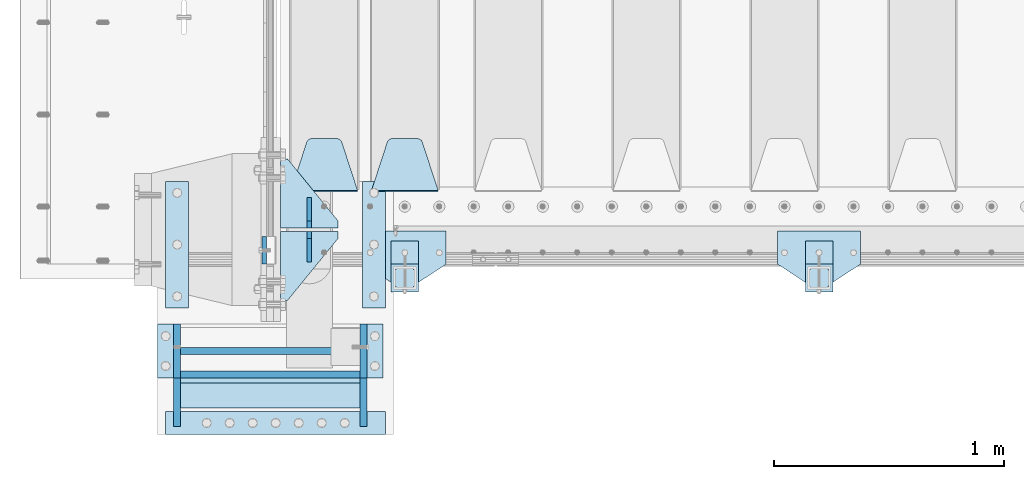
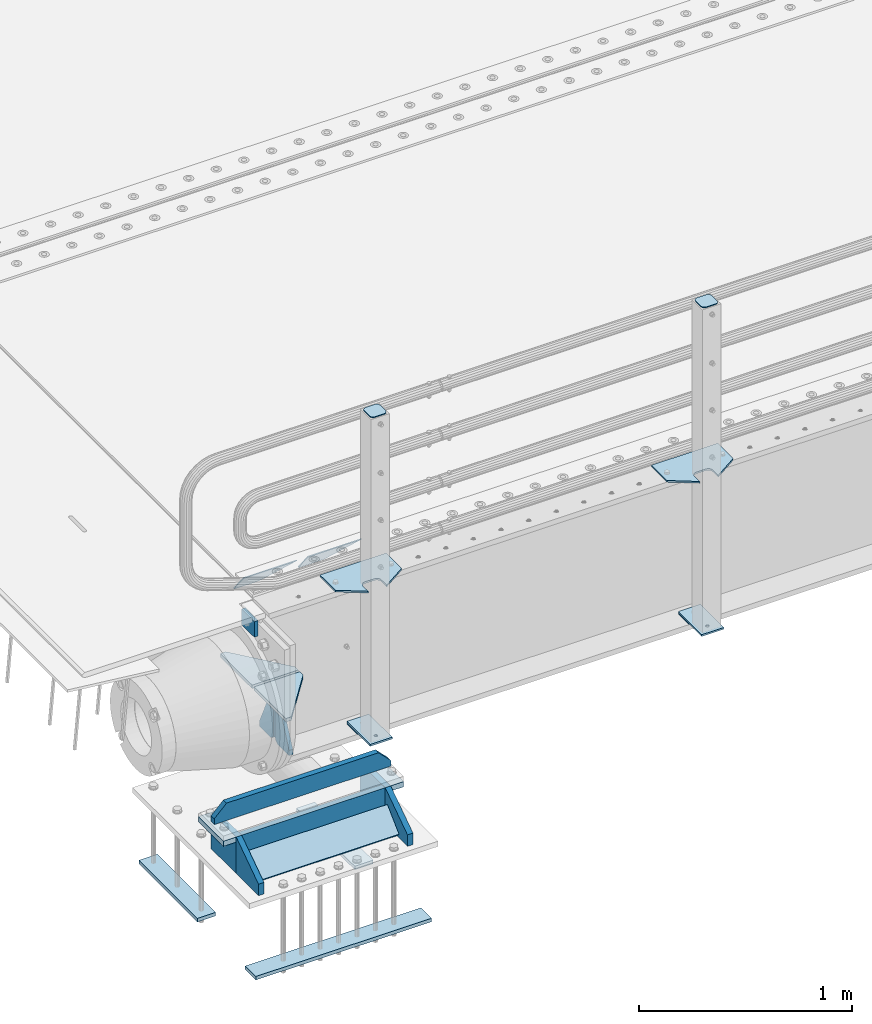
# One storey, part 196 of 247: 27 plates.
"""IFC2X3 building model written with IfcOpenShell, lengths in millimetres."""

import ifcopenshell
import ifcopenshell.guid

model = None  # the IFC model being written
_history = None  # IfcOwnerHistory: only IFC2X3 demands one
_inside = {}  # id of a spatial element -> (the spatial element, [elements in it])
_under = {}  # id of a project, library or spatial element -> (it, [spatial elements below it])
_declared = {}  # id of a project -> (the project, [libraries it declares])
_typed = {}  # id of a type object -> (the type object, [elements of that type])
_made_of = {}  # id of a material, layer set ... -> (it, [elements and type objects made of it])


def new_model(schema):
    """Start an empty IFC model of exactly this schema.

    Asked for "IFC4X3", IfcOpenShell would pick the latest addendum, in which some entities
    have other attributes; the version numbers below select the first issue.
    IFC2X3 requires an IfcOwnerHistory on every rooted entity: one is made here for all.
    """
    global model, _history
    if schema == "IFC4X3":
        model = ifcopenshell.file(schema_version=(4, 3, 0, 0))
    else:
        model = ifcopenshell.file(schema=schema)
    _inside.clear()
    _under.clear()
    _declared.clear()
    _typed.clear()
    _made_of.clear()
    _history = None
    if model.schema == "IFC2X3":
        org = make("IfcOrganization", Name="unknown")
        user = make(
            "IfcPersonAndOrganization",
            ThePerson=make("IfcPerson", FamilyName="unknown"),
            TheOrganization=org,
        )
        app = make(
            "IfcApplication",
            ApplicationDeveloper=org,
            Version="unknown",
            ApplicationFullName="unknown",
            ApplicationIdentifier="unknown",
        )
        _history = make(
            "IfcOwnerHistory",
            OwningUser=user,
            OwningApplication=app,
            ChangeAction="ADDED",
            CreationDate=0,
        )
    return model


def make(cls, **values):
    """One entity of the class cls with the attributes given. An attribute that is None is left unset."""
    return model.create_entity(
        cls, **{name: value for name, value in values.items() if value is not None}
    )


def rooted(cls, **values):
    """An entity with a GlobalId (a new one), such as an element, a storey or a relation."""
    return make(cls, GlobalId=ifcopenshell.guid.new(), OwnerHistory=_history, **values)


def si_unit(unit_type, name, prefix=None):
    """IfcSIUnit, for example si_unit("LENGTHUNIT", "METRE", prefix="MILLI")."""
    return make("IfcSIUnit", UnitType=unit_type, Prefix=prefix, Name=name)


def assignment(units):
    """IfcUnitAssignment: the units of a project."""
    return None if units is None else make("IfcUnitAssignment", Units=units)


def point(xyz):
    """IfcCartesianPoint."""
    return None if xyz is None else make("IfcCartesianPoint", Coordinates=xyz)


def direction(xyz):
    """IfcDirection."""
    return None if xyz is None else make("IfcDirection", DirectionRatios=xyz)


def frame(location, z_axis=None, x_axis=None):
    """IfcAxis2Placement3D, a coordinate frame: its origin and axes. An axis left out is left unset."""
    return make(
        "IfcAxis2Placement3D",
        Location=point(location),
        Axis=direction(z_axis),
        RefDirection=direction(x_axis),
    )


def origin_with_axes():
    """The frame at (0, 0, 0) with the z axis (0, 0, 1) and the x axis (1, 0, 0) written out."""
    return frame((0.0, 0.0, 0.0), z_axis=(0.0, 0.0, 1.0), x_axis=(1.0, 0.0, 0.0))


def place(relative_to, where):
    """IfcLocalPlacement: puts the frame where relative to a parent placement (None: the world)."""
    return make(
        "IfcLocalPlacement", PlacementRelTo=relative_to, RelativePlacement=where
    )


def context(
    kind, dimensions, precision=None, world=None, true_north=None, identifier=None
):
    """IfcGeometricRepresentationContext, for example the 3D "Model" context."""
    return make(
        "IfcGeometricRepresentationContext",
        ContextIdentifier=identifier,
        ContextType=kind,
        CoordinateSpaceDimension=dimensions,
        Precision=precision,
        WorldCoordinateSystem=world,
        TrueNorth=true_north,
    )


def subcontext(parent, identifier, kind, view, scale=None):
    """IfcGeometricRepresentationSubContext, for example "Body" below "Model"."""
    return make(
        "IfcGeometricRepresentationSubContext",
        ContextIdentifier=identifier,
        ContextType=kind,
        ParentContext=parent,
        TargetScale=scale,
        TargetView=view,
    )


def project(units=None, contexts=None):
    """IfcProject with its units and contexts."""
    return rooted(
        "IfcProject",
        Name="project",
        RepresentationContexts=contexts,
        UnitsInContext=assignment(units),
    )


def spatial(cls, under=None, at=None, **own):
    """A site, building, storey or space (cls), placed at a placement, below another one or the project."""
    s = rooted(cls, ObjectPlacement=at, **own)
    if under is not None:
        _under.setdefault(under.id(), (under, []))[1].append(s)
    return s


def faces_of(points, faces, orient=None, outer=None):
    """IfcFace entities. A face is a list of loops; a loop is a list of indices into points, from 0.

    orient and outer hold one flag for each loop. By default every Orientation is true, the
    first loop of a face is its IfcFaceOuterBound and the others are IfcFaceBound.
    """
    made = []
    for i, loops in enumerate(faces):
        bounds = []
        for j, loop in enumerate(loops):
            is_outer = j == 0 if outer is None else outer[i][j]
            bounds.append(
                make(
                    "IfcFaceOuterBound" if is_outer else "IfcFaceBound",
                    Bound=make("IfcPolyLoop", Polygon=[points[k] for k in loop]),
                    Orientation=True if orient is None else orient[i][j],
                )
            )
        made.append(make("IfcFace", Bounds=bounds))
    return made


def faceted_brep(points, faces, orient=None, outer=None, voids=None):
    """IfcFacetedBrep: a solid bounded by flat faces; with voids (closed shells), ...WithVoids."""
    shared = [point(p) for p in points]
    hull = make("IfcClosedShell", CfsFaces=faces_of(shared, faces, orient, outer))
    if voids is None:
        return make("IfcFacetedBrep", Outer=hull)
    return make(
        "IfcFacetedBrepWithVoids",
        Outer=hull,
        Voids=[
            make(cls, CfsFaces=faces_of(shared, fs, o, b)) for cls, fs, o, b in voids
        ],
    )


def shape(context_of_items, identifier, shape_type, items):
    """IfcShapeRepresentation: the items that make up one representation, for example the "Body"."""
    return make(
        "IfcShapeRepresentation",
        ContextOfItems=context_of_items,
        RepresentationIdentifier=identifier,
        RepresentationType=shape_type,
        Items=items,
    )


def material(Name=None, Category=None):
    """IfcMaterial."""
    return make("IfcMaterial", Name=Name, Category=Category)


def made_of(thing, what):
    """Note that an element or type object is made of a material, layer set ...; save() writes the relation."""
    if what is not None:
        _made_of.setdefault(what.id(), (what, []))[1].append(thing)
    return thing


def type_object(cls, material=None, **own):
    """A type object (cls), such as IfcWallType, which elements share."""
    return made_of(rooted(cls, **own), material)


def element(
    cls,
    number,
    at=None,
    inside=None,
    cuts=None,
    type_object=None,
    material=None,
    context=None,
    identifier="Body",
    shape_type=None,
    held_by="IfcProductDefinitionShape",
    body=None,
    shapes=None,
    **own,
):
    """One element of the class cls, such as IfcWall. Its Tag is "e" and its number.

    at: its placement. inside: the storey or other place that contains it. cuts: it is an
    opening in that element (IfcRelVoidsElement). A single representation is given by context,
    identifier, shape_type and body (its items); several are given by shapes. held_by: the class
    of the entity that holds the representations. save() writes the other relations.
    """
    e = rooted(cls, Tag="e%d" % number, ObjectPlacement=at, **own)
    if body is not None:
        shapes = [shape(context, identifier, shape_type, body)]
    if shapes is not None:
        e.Representation = make(held_by, Representations=shapes)
    if inside is not None:
        _inside.setdefault(inside.id(), (inside, []))[1].append(e)
    if cuts is not None:
        rooted(
            "IfcRelVoidsElement", RelatingBuildingElement=cuts, RelatedOpeningElement=e
        )
    if type_object is not None:
        _typed.setdefault(type_object.id(), (type_object, []))[1].append(e)
    return made_of(e, material)


def aggregate(whole, parts):
    """IfcRelAggregates: a whole, such as a stair, and the parts it consists of."""
    return rooted("IfcRelAggregates", RelatingObject=whole, RelatedObjects=parts)


def save(model, path):
    """Write the relations noted so far, then the file.

    IfcRelAggregates (storeys below a building ...), IfcRelContainedInSpatialStructure (elements
    in a storey), IfcRelDefinesByType, IfcRelAssociatesMaterial and IfcRelDeclares: one each for
    every whole, place, type object, material and project.
    """
    for whole, parts in _under.values():
        aggregate(whole, parts)
    for where, things in _inside.values():
        rooted(
            "IfcRelContainedInSpatialStructure",
            RelatedElements=things,
            RelatingStructure=where,
        )
    for kind, things in _typed.values():
        rooted("IfcRelDefinesByType", RelatedObjects=things, RelatingType=kind)
    for what, things in _made_of.values():
        rooted("IfcRelAssociatesMaterial", RelatedObjects=things, RelatingMaterial=what)
    for by, libraries in _declared.values():
        rooted("IfcRelDeclares", RelatingContext=by, RelatedDefinitions=libraries)
    model.write(path)


model = new_model("IFC2X3")

# Units and contexts
model_context = context("Model", 3, precision=1e-05, world=origin_with_axes())
body_context = subcontext(model_context, "Body", "Model", "MODEL_VIEW")
ifc_project = project(units=[si_unit("LENGTHUNIT", "METRE", prefix="MILLI"), si_unit("AREAUNIT", "SQUARE_METRE"), si_unit("VOLUMEUNIT", "CUBIC_METRE"), si_unit("MASSUNIT", "GRAM", prefix="KILO"), si_unit("TIMEUNIT", "SECOND"), si_unit("PLANEANGLEUNIT", "RADIAN"), si_unit("SOLIDANGLEUNIT", "STERADIAN"), si_unit("THERMODYNAMICTEMPERATUREUNIT", "DEGREE_CELSIUS"), si_unit("LUMINOUSINTENSITYUNIT", "LUMEN")], contexts=[model_context])

# Site, building, storey
site_placement = place(None, origin_with_axes())
site = spatial("IfcSite", under=ifc_project, at=site_placement, CompositionType="ELEMENT")
building_placement = place(site_placement, origin_with_axes())
building = spatial("IfcBuilding", under=site, at=building_placement, Name="Standard", CompositionType="ELEMENT")
storey_placement = place(building_placement, origin_with_axes())
storey = spatial("IfcBuildingStorey", under=building, at=storey_placement, Name="Undefined", CompositionType="ELEMENT", Elevation=0.0)

# Plates
ifc_material_1 = material(Name="STEEL/S355N")
plate_type_1 = type_object("IfcPlateType", PredefinedType="NOTDEFINED")
plate_1_placement = place(storey_placement, frame((-60.0000000000158, -29.9995540187374, -106.000105640918), z_axis=(1.00000000012752e-09, -0.999999999987744, -4.95099999993936e-06), x_axis=(0.0, -4.95099999998473e-06, 0.999999999987744)))
element("IfcPlate", 1, at=plate_1_placement, inside=storey, type_object=plate_type_1, material=ifc_material_1, context=body_context, shape_type="Brep", body=[
    faceted_brep([(-5.6843418860808e-14, -9.99999999999989, 3.5527136788005e-15), (4.32933688898629e-10, -10.0, 120.0), (4.32933688898629e-10, 10.0, 120.0), (-5.6843418860808e-14, 10.0000000000001, 3.5527136788005e-15), (90.0, -10.0, 120.0), (90.0, 10.0, 120.0), (90.0, -10.0, 1.09139364212751e-11), (90.0, 10.0, 1.09139364212751e-11)], [[[0, 1, 2, 3]], [[1, 4, 5, 2]], [[4, 6, 7, 5]], [[6, 0, 3, 7]], [[5, 7, 3, 2]], [[6, 4, 1, 0]]]),
])
plate_type_2 = type_object("IfcPlateType", PredefinedType="NOTDEFINED")
plate_2_placement = place(storey_placement, frame((695.0, 168.232233047034, -1.76776695296758), z_axis=(0.0, 0.707106781186548, -0.707106781186547), x_axis=(-1.0, 0.0, 0.0)))
element("IfcPlate", 2, at=plate_2_placement, inside=storey, type_object=plate_type_2, material=ifc_material_1, context=body_context, shape_type="Brep", body=[
    faceted_brep([(0.0, -2.49999999999909, 0.0), (69.345504679477, -2.5, 300.17173142483), (69.345504679477, 2.50000000000091, 300.171731424831), (0.0, 2.5, -9.09494701772928e-13), (70.9274061199576, -2.5, 304.897442415399), (70.9274061199576, 2.50000000000091, 304.8974424154), (73.3818627772307, -2.49999999999909, 309.234538108527), (73.3818627772307, 2.5, 309.234538108526), (76.6187032999551, -2.5, 313.023683126102), (76.6187032999551, 2.50000000000091, 313.023683126102), (80.5190132704993, -2.49999999999909, 316.125672595371), (80.5190132704993, 2.50000000000091, 316.125672595372), (84.9395038596849, -2.49999999999909, 318.426546230476), (84.9395038596849, 2.5, 318.426546230475), (89.7177759439219, -2.5, 319.841774983274), (89.7177759439219, 2.50000000000091, 319.841774983275), (94.678286292652, -2.5, 320.319366455077), (94.678286292652, 2.50000000000091, 320.319366455077), (195.321713707348, -2.5, 320.319366455077), (195.321713707348, 2.50000000000091, 320.319366455077), (200.282224056078, -2.5, 319.841774983274), (200.282224056078, 2.50000000000091, 319.841774983275), (205.060496140315, -2.5, 318.426546230475), (205.060496140315, 2.5, 318.426546230474), (209.480986729501, -2.49999999999818, 316.12567259537), (209.480986729501, 2.50000000000091, 316.12567259537), (213.381296700045, -2.5, 313.023683126101), (213.381296700045, 2.50000000000091, 313.023683126101), (216.618137222769, -2.5, 309.234538108525), (216.618137222769, 2.5, 309.234538108525), (219.072593880042, -2.49999999999909, 304.897442415398), (219.072593880042, 2.5, 304.897442415398), (220.654495320523, -2.5, 300.17173142483), (220.654495320523, 2.50000000000091, 300.171731424831), (290.0, -2.49999999999909, 0.0), (290.0, 2.5, -9.09494701772928e-13)], [[[0, 1, 2, 3]], [[1, 4, 5, 2]], [[4, 6, 7, 5]], [[6, 8, 9, 7]], [[8, 10, 11, 9]], [[10, 12, 13, 11]], [[12, 14, 15, 13]], [[14, 16, 17, 15]], [[16, 18, 19, 17]], [[18, 20, 21, 19]], [[20, 22, 23, 21]], [[22, 24, 25, 23]], [[24, 26, 27, 25]], [[26, 28, 29, 27]], [[28, 30, 31, 29]], [[30, 32, 33, 31]], [[32, 34, 35, 33]], [[34, 0, 3, 35]], [[5, 7, 9, 11, 13, 15, 17, 19, 21, 23, 25, 27, 29, 31, 33, 35, 3, 2]], [[34, 32, 30, 28, 26, 24, 22, 20, 18, 16, 14, 12, 10, 8, 6, 4, 1, 0]]]),
])
plate_3_placement = place(storey_placement, frame((345.0, 168.232233047034, -1.76776695296758), z_axis=(0.0, 0.707106781186548, -0.707106781186547), x_axis=(-1.0, 0.0, 0.0)))
element("IfcPlate", 3, at=plate_3_placement, inside=storey, type_object=plate_type_2, material=ifc_material_1, context=body_context, shape_type="Brep", body=[
    faceted_brep([(0.0, -2.49999999999909, 0.0), (69.345504679477, -2.5, 300.17173142483), (69.345504679477, 2.50000000000091, 300.171731424831), (0.0, 2.5, -9.09494701772928e-13), (70.9274061199576, -2.5, 304.897442415399), (70.9274061199576, 2.50000000000091, 304.8974424154), (73.3818627772307, -2.49999999999909, 309.234538108527), (73.3818627772307, 2.5, 309.234538108526), (76.6187032999551, -2.5, 313.023683126102), (76.6187032999551, 2.50000000000091, 313.023683126102), (80.5190132704993, -2.49999999999909, 316.125672595371), (80.5190132704993, 2.50000000000091, 316.125672595372), (84.9395038596849, -2.49999999999909, 318.426546230476), (84.9395038596849, 2.5, 318.426546230475), (89.7177759439219, -2.5, 319.841774983274), (89.7177759439219, 2.50000000000091, 319.841774983275), (94.678286292652, -2.5, 320.319366455077), (94.678286292652, 2.50000000000091, 320.319366455077), (195.321713707348, -2.5, 320.319366455077), (195.321713707348, 2.50000000000091, 320.319366455077), (200.282224056078, -2.5, 319.841774983274), (200.282224056078, 2.50000000000091, 319.841774983275), (205.060496140315, -2.5, 318.426546230475), (205.060496140315, 2.5, 318.426546230474), (209.480986729501, -2.49999999999818, 316.12567259537), (209.480986729501, 2.50000000000091, 316.12567259537), (213.381296700045, -2.5, 313.023683126101), (213.381296700045, 2.50000000000091, 313.023683126101), (216.618137222769, -2.5, 309.234538108525), (216.618137222769, 2.5, 309.234538108525), (219.072593880042, -2.49999999999909, 304.897442415398), (219.072593880042, 2.5, 304.897442415398), (220.654495320523, -2.5, 300.17173142483), (220.654495320523, 2.50000000000091, 300.171731424831), (290.0, -2.49999999999909, 0.0), (290.0, 2.5, -9.09494701772928e-13)], [[[0, 1, 2, 3]], [[1, 4, 5, 2]], [[4, 6, 7, 5]], [[6, 8, 9, 7]], [[8, 10, 11, 9]], [[10, 12, 13, 11]], [[12, 14, 15, 13]], [[14, 16, 17, 15]], [[16, 18, 19, 17]], [[18, 20, 21, 19]], [[20, 22, 23, 21]], [[22, 24, 25, 23]], [[24, 26, 27, 25]], [[26, 28, 29, 27]], [[28, 30, 31, 29]], [[30, 32, 33, 31]], [[32, 34, 35, 33]], [[34, 0, 3, 35]], [[5, 7, 9, 11, 13, 15, 17, 19, 21, 23, 25, 27, 29, 31, 33, 35, 3, 2]], [[34, 32, 30, 28, 26, 24, 22, 20, 18, 16, 14, 12, 10, 8, 6, 4, 1, 0]]]),
])
plate_type_3 = type_object("IfcPlateType", PredefinedType="NOTDEFINED")
plate_4_placement = place(storey_placement, frame((355.000000373937, -765.357137390209, -1017.14966545662), z_axis=(-1.0, 0.0, 0.0), x_axis=(1.99999983730402e-09, 0.723355636225728, 0.690475650215467)))
element("IfcPlate", 4, at=plate_4_placement, inside=storey, type_object=plate_type_3, material=ifc_material_1, context=body_context, shape_type="Brep", body=[
    faceted_brep([(0.0, -15.0, 0.0), (2.15506588574499e-07, -15.0, 779.0), (2.15505679079797e-07, 15.0000000000009, 779.0), (0.0, 15.0, 0.0), (152.069061494803, -14.9999999999991, 779.0), (152.069061494803, 15.0000000000009, 779.0), (152.069061279297, -14.9999999999991, 0.0), (152.069061279298, 15.0000000000009, 5.6843418860808e-14)], [[[0, 1, 2, 3]], [[1, 4, 5, 2]], [[4, 6, 7, 5]], [[6, 0, 3, 7]], [[5, 7, 3, 2]], [[6, 4, 1, 0]]]),
])
plate_type_4 = type_object("IfcPlateType", PredefinedType="NOTDEFINED")
for number, where, z_axis, x_axis in (
    (5, (366.000001649994, -340.000001203735, -1468.0), (0.0, 1.0, 0.0), (1.0, 0.0, 0.0)),
    (6, (-488.999998350006, -339.999998638762, -1468.0), (0.0, 1.0, 0.0), (1.0, 0.0, 0.0)),
):
    element("IfcPlate", number, at=place(storey_placement, frame(where, z_axis=z_axis, x_axis=x_axis)), inside=storey, type_object=plate_type_4, material=ifc_material_1, context=body_context, shape_type="Brep", body=[
        faceted_brep([(-5.6843418860808e-14, -9.99999999999989, 3.5527136788005e-15), (1.00943600500614e-06, -10.0, 550.0), (1.00943600500614e-06, 10.0, 550.0), (-5.6843418860808e-14, 10.0000000000001, 3.5527136788005e-15), (100.000000000004, -10.0, 550.0), (100.000000000004, 10.0, 550.0), (100.0, -10.0, 0.0), (100.0, 10.0, 0.0)], [[[0, 1, 2, 3]], [[1, 4, 5, 2]], [[4, 6, 7, 5]], [[6, 0, 3, 7]], [[5, 7, 3, 2]], [[6, 4, 1, 0]]]),
    ])
plate_5_placement = place(storey_placement, frame((-488.999999999989, -889.999998638762, -1468.0), z_axis=(0.0, 1.0, 0.0), x_axis=(1.0, 0.0, 0.0)))
element("IfcPlate", 7, at=plate_5_placement, inside=storey, type_object=plate_type_4, material=ifc_material_1, context=body_context, shape_type="Brep", body=[
    faceted_brep([(-5.6843418860808e-14, -9.99999999999989, 3.5527136788005e-15), (0.0, -10.0, 100.0), (0.0, 10.0, 100.0), (-5.6843418860808e-14, 10.0000000000001, 3.5527136788005e-15), (955.0, -10.0, 100.0), (955.0, 10.0, 100.0), (955.0, -10.0, 0.0), (955.0, 10.0, 0.0)], [[[0, 1, 2, 3]], [[1, 4, 5, 2]], [[4, 6, 7, 5]], [[6, 0, 3, 7]], [[5, 7, 3, 2]], [[6, 4, 1, 0]]]),
])
plate_type_5 = type_object("IfcPlateType", PredefinedType="NOTDEFINED")
plate_6_placement = place(storey_placement, frame((370.000001439999, -410.000002681972, -818.000000000005), z_axis=(0.0, 0.0, -1.0), x_axis=(0.0, -0.999999999999548, -9.5100000000016e-07)))
element("IfcPlate", 8, at=plate_6_placement, inside=storey, type_object=plate_type_5, material=ifc_material_1, context=body_context, shape_type="Brep", body=[
    faceted_brep([(0.0, -15.0, 0.0), (1.81898940354586e-12, -15.0, 210.0), (0.0, 15.0, 210.0), (0.0, 15.0, 0.0), (235.000000000002, -15.0, 210.0), (235.0, 15.0, 210.0), (235.0, -15.0, 0.0), (235.0, 15.0, 0.0)], [[[0, 1, 2, 3]], [[1, 4, 5, 2]], [[4, 6, 7, 5]], [[6, 0, 3, 7]], [[5, 7, 3, 2]], [[6, 4, 1, 0]]]),
])
for number, where, z_axis, x_axis in (
    (9, (370.00000010501, -855.000002681972, -1028.0), (0.0, 0.0, 1.0), (0.0, 1.0, 0.0)),
    (10, (-438.99999989499, -855.000000254997, -1028.0), (0.0, 0.0, 1.0), (0.0, 1.0, 0.0)),
):
    element("IfcPlate", number, at=place(storey_placement, frame(where, z_axis=z_axis, x_axis=x_axis)), inside=storey, type_object=plate_type_5, material=ifc_material_1, context=body_context, shape_type="Brep", body=[
        faceted_brep([(0.0, -15.0, 0.0), (-1.81898940354586e-12, -15.0, 66.0), (0.0, 15.0, 66.0), (0.0, 15.0, 0.0), (209.999999999998, -15.0, 210.0), (210.0, 15.0, 210.0), (209.999999999998, -15.0, 0.0), (210.0, 15.0, 0.0)], [[[0, 1, 2, 3]], [[1, 4, 5, 2]], [[4, 6, 7, 5]], [[6, 0, 3, 7]], [[5, 7, 3, 2]], [[6, 4, 1, 0]]]),
    ])
plate_7_placement = place(storey_placement, frame((-423.999999219996, -630.000000299997, -1028.0), z_axis=(1.0, 0.0, 0.0), x_axis=(0.0, 0.0, 1.0)))
element("IfcPlate", 11, at=plate_7_placement, inside=storey, type_object=plate_type_5, material=ifc_material_1, context=body_context, shape_type="Brep", body=[
    faceted_brep([(0.0, -15.0, 0.0), (2.15506588574499e-07, -15.0, 779.0), (2.15505679079797e-07, 15.0000000000009, 779.0), (0.0, 15.0, 0.0), (210.0, -15.0, 779.0), (210.0, 15.0, 779.0), (209.999999999998, -15.0, 0.0), (210.0, 15.0, 0.0)], [[[0, 1, 2, 3]], [[1, 4, 5, 2]], [[4, 6, 7, 5]], [[6, 0, 3, 7]], [[5, 7, 3, 2]], [[6, 4, 1, 0]]]),
])
plate_8_placement = place(storey_placement, frame((-438.999998560004, -410.000000254997, -818.000000000004), z_axis=(0.0, 0.0, -1.0), x_axis=(0.0, -0.999999999999548, -9.5100000000016e-07)))
element("IfcPlate", 12, at=plate_8_placement, inside=storey, type_object=plate_type_5, material=ifc_material_1, context=body_context, shape_type="Brep", body=[
    faceted_brep([(0.0, -15.0, 0.0), (1.81898940354586e-12, -15.0, 210.0), (0.0, 15.0, 210.0), (0.0, 15.0, 0.0), (235.000000000002, -15.0, 210.0), (235.0, 15.0, 210.0), (235.0, -15.0, 0.0), (235.0, 15.0, 0.0)], [[[0, 1, 2, 3]], [[1, 4, 5, 2]], [[4, 6, 7, 5]], [[6, 0, 3, 7]], [[5, 7, 3, 2]], [[6, 4, 1, 0]]]),
])
plate_type_6 = type_object("IfcPlateType", PredefinedType="NOTDEFINED")
plate_9_placement = place(storey_placement, frame((-513.999998912499, -527.50000003, -788.000000000004), z_axis=(0.0, 0.0, 1.0), x_axis=(1.0, 0.0, 0.0)))
element("IfcPlate", 13, at=plate_9_placement, inside=storey, type_object=plate_type_6, material=ifc_material_1, context=body_context, shape_type="Brep", body=[
    faceted_brep([(0.0, -15.0, 0.0), (0.0, -15.0, 33.0), (0.0, 15.0, 33.0), (0.0, 15.0, 0.0), (67.0, -15.0, 100.0), (67.0, 15.0, 100.0), (892.0, -15.0000000000018, 100.0), (892.0, 14.9999999999982, 100.0), (959.0, -15.0, 33.0), (959.0, 15.0, 33.0), (959.0, -15.0, 0.0), (959.0, 15.0, 0.0)], [[[0, 1, 2, 3]], [[1, 4, 5, 2]], [[4, 6, 7, 5]], [[6, 8, 9, 7]], [[8, 10, 11, 9]], [[10, 0, 3, 11]], [[5, 7, 9, 11, 3, 2]], [[10, 8, 6, 4, 1, 0]]]),
])
plate_type_7 = type_object("IfcPlateType", PredefinedType="NOTDEFINED")
for number, where, z_axis, x_axis in (
    (14, (385.000000735005, -645.000002726971, -833.000000000004), (1.0, 0.0, 0.0), (0.0, 1.0, 0.0)),
    (15, (-523.999999264995, -645.0, -833.000000000004), (1.0, 0.0, 0.0), (0.0, 1.0, 0.0)),
):
    element("IfcPlate", number, at=place(storey_placement, frame(where, z_axis=z_axis, x_axis=x_axis)), inside=storey, type_object=plate_type_7, material=ifc_material_1, context=body_context, shape_type="Brep", body=[
        faceted_brep([(0.0, -15.0, 0.0), (0.0, -15.0, 70.0), (0.0, 15.0, 70.0), (0.0, 15.0, 0.0), (235.0, -15.0, 70.0), (235.0, 15.0, 70.0), (235.0, -15.0, 0.0), (235.0, 15.0, 0.0)], [[[0, 1, 2, 3]], [[1, 4, 5, 2]], [[4, 6, 7, 5]], [[6, 0, 3, 7]], [[5, 7, 3, 2]], [[6, 4, 1, 0]]]),
    ])
plate_type_8 = type_object("IfcPlateType", PredefinedType="NOTDEFINED")
for number, where, z_axis, x_axis in (
    (16, (259.999999999996, 8.0, -515.0), (0.0, 1.0, 0.0), (-1.0, 0.0, 0.0)),
    (17, (259.999999999996, -8.0, -515.0), (0.0, -0.999999999999548, -9.5100000000016e-07), (-1.0, 0.0, 0.0)),
):
    element("IfcPlate", number, at=place(storey_placement, frame(where, z_axis=z_axis, x_axis=x_axis)), inside=storey, type_object=plate_type_8, material=ifc_material_1, context=body_context, shape_type="Brep", body=[
        faceted_brep([(-5.6843418860808e-14, -9.99999999999989, 3.5527136788005e-15), (0.0, -10.0, 30.0), (0.0, 10.0, 30.0), (-5.6843418860808e-14, 10.0000000000001, 3.5527136788005e-15), (220.0, -10.0, 300.0), (220.0, 10.0, 300.0), (250.0, -10.0, 300.0), (250.0, 10.0, 300.0), (250.0, -10.0, 0.0), (250.0, 10.0, 0.0)], [[[0, 1, 2, 3]], [[1, 4, 5, 2]], [[4, 6, 7, 5]], [[6, 8, 9, 7]], [[8, 0, 3, 9]], [[5, 7, 9, 3, 2]], [[8, 6, 4, 1, 0]]]),
    ])
plate_type_9 = type_object("IfcPlateType", PredefinedType="NOTDEFINED")
for number, where, z_axis, x_axis in (
    (18, (135.0, 140.0, -860.0), (0.0, 0.0, 1.0), (0.0, -0.999999999999548, -9.5100000000016e-07)),
    (19, (135.0, -140.0, -860.0), (0.0, 0.0, 1.0), (0.0, 1.0, 0.0)),
):
    element("IfcPlate", number, at=place(storey_placement, frame(where, z_axis=z_axis, x_axis=x_axis)), inside=storey, type_object=plate_type_9, material=ifc_material_1, context=body_context, shape_type="Brep", body=[
        faceted_brep([(-5.6843418860808e-14, -9.99999999999989, 3.5527136788005e-15), (0.0, -10.0, 30.0), (0.0, 10.0, 30.0), (-5.6843418860808e-14, 10.0000000000001, 3.5527136788005e-15), (102.0, -10.0, 250.0), (102.0, 10.0, 250.0), (132.0, -10.0, 250.0), (132.0, 10.0, 250.0), (132.0, -10.0, 30.0), (132.0, 10.0, 30.0), (131.544232590366, -10.0, 24.790554669992), (131.544232590366, 10.0, 24.790554669992), (130.190778623577, -10.0, 19.7393957002299), (130.190778623577, 10.0, 19.7393957002299), (127.980762113533, -10.0, 15.0), (127.980762113533, 10.0, 15.0), (124.981333293569, -10.0, 10.7163717094038), (124.981333293569, 10.0, 10.7163717094038), (121.283628290596, -10.0, 7.01866670643062), (121.283628290596, 10.0, 7.01866670643062), (117.0, -10.0, 4.01923788646684), (117.0, 10.0, 4.01923788646684), (112.26060429977, -10.0, 1.80922137642278), (112.26060429977, 10.0, 1.80922137642278), (107.209445330008, -10.0, 0.455767409633722), (107.209445330008, 10.0, 0.455767409633722), (102.0, -10.0, 0.0), (102.0, 10.0, 0.0)], [[[0, 1, 2, 3]], [[1, 4, 5, 2]], [[4, 6, 7, 5]], [[6, 8, 9, 7]], [[8, 10, 11, 9]], [[10, 12, 13, 11]], [[12, 14, 15, 13]], [[14, 16, 17, 15]], [[16, 18, 19, 17]], [[18, 20, 21, 19]], [[20, 22, 23, 21]], [[22, 24, 25, 23]], [[24, 26, 27, 25]], [[26, 0, 3, 27]], [[5, 7, 9, 11, 13, 15, 17, 19, 21, 23, 25, 27, 3, 2]], [[26, 24, 22, 20, 18, 16, 14, 12, 10, 8, 6, 4, 1, 0]]]),
    ])
ifc_material_2 = material(Name="STEEL/S355J2")
plate_type_10 = type_object("IfcPlateType", PredefinedType="NOTDEFINED")
plate_10_placement = place(storey_placement, frame((2530.0, -4.99999999999636, 5.00000000004911), z_axis=(0.0, -0.999999999999548, -9.5100000000016e-07), x_axis=(-1.0, 0.0, 0.0)))
element("IfcPlate", 20, at=plate_10_placement, inside=storey, type_object=plate_type_10, material=ifc_material_2, context=body_context, shape_type="Brep", body=[
    faceted_brep([(9.04219632502645e-09, -5.00000000143385, -2.89173840428703e-09), (2.31396552408114e-06, -5.0, 145.0), (2.31396552408114e-06, 5.0, 145.0), (7.66340235713869e-09, 4.99999999856618, -2.89173840428703e-09), (130.0, -5.0, 230.0), (130.0, 5.0, 230.0), (130.0, -5.0, 180.0), (130.0, 5.0, 180.0), (130.48036798992, -5.0, 175.122741949597), (130.48036798992, 5.0, 175.122741949597), (131.903011687218, -5.0, 170.432914190873), (131.903011687218, 5.0, 170.432914190873), (134.213259692437, -5.0, 166.11074417451), (134.213259692437, 5.0, 166.11074417451), (137.322330470337, -5.0, 162.322330470337), (137.322330470337, 5.0, 162.322330470337), (141.11074417451, -5.0, 159.213259692437), (141.11074417451, 5.0, 159.213259692437), (145.432914190873, -5.0, 156.903011687218), (145.432914190873, 5.0, 156.903011687218), (150.122741949597, -5.0, 155.48036798992), (150.122741949597, 5.0, 155.48036798992), (155.0, -5.0, 155.0), (155.0, 5.0, 155.0), (205.0, -5.0, 155.0), (205.0, 5.0, 155.0), (209.877258050403, -5.0, 155.48036798992), (209.877258050403, 5.0, 155.48036798992), (214.567085809127, -5.0, 156.903011687218), (214.567085809127, 5.0, 156.903011687218), (218.88925582549, -5.0, 159.213259692437), (218.88925582549, 5.0, 159.213259692437), (222.677669529663, -5.0, 162.322330470337), (222.677669529663, 5.0, 162.322330470337), (225.786740307563, -5.0, 166.11074417451), (225.786740307563, 5.0, 166.11074417451), (228.096988312782, -5.0, 170.432914190873), (228.096988312782, 5.0, 170.432914190873), (229.51963201008, -5.0, 175.122741949597), (229.51963201008, 5.0, 175.122741949597), (230.0, -5.0, 180.0), (230.0, 5.0, 180.0), (230.0, -5.0, 230.0), (230.0, 5.0, 230.0), (360.0, -5.0, 145.0), (360.0, 5.0, 145.0), (360.0, -5.0, -7.27595761418343e-12), (360.0, 5.0, -7.27595761418343e-12)], [[[0, 1, 2, 3]], [[1, 4, 5, 2]], [[4, 6, 7, 5]], [[6, 8, 9, 7]], [[8, 10, 11, 9]], [[10, 12, 13, 11]], [[12, 14, 15, 13]], [[14, 16, 17, 15]], [[16, 18, 19, 17]], [[18, 20, 21, 19]], [[20, 22, 23, 21]], [[22, 24, 25, 23]], [[24, 26, 27, 25]], [[26, 28, 29, 27]], [[28, 30, 31, 29]], [[30, 32, 33, 31]], [[32, 34, 35, 33]], [[34, 36, 37, 35]], [[36, 38, 39, 37]], [[38, 40, 41, 39]], [[40, 42, 43, 41]], [[42, 44, 45, 43]], [[44, 46, 47, 45]], [[46, 0, 3, 47]], [[5, 7, 9, 11, 13, 15, 17, 19, 21, 23, 25, 27, 29, 31, 33, 35, 37, 39, 41, 43, 45, 47, 3, 2]], [[46, 44, 42, 40, 38, 36, 34, 32, 30, 28, 26, 24, 22, 20, 18, 16, 14, 12, 10, 8, 6, 4, 1, 0]]]),
])
plate_11_placement = place(storey_placement, frame((730.0, -4.99999999999636, 5.00000000004911), z_axis=(0.0, -0.999999999999548, -9.5100000000016e-07), x_axis=(-1.0, 0.0, 0.0)))
element("IfcPlate", 21, at=plate_11_placement, inside=storey, type_object=plate_type_10, material=ifc_material_2, context=body_context, shape_type="Brep", body=[
    faceted_brep([(9.04219632502645e-09, -5.00000000143385, -2.89173840428703e-09), (2.31396552408114e-06, -5.0, 145.0), (2.31396552408114e-06, 5.0, 145.0), (7.66340235713869e-09, 4.99999999856618, -2.89173840428703e-09), (130.0, -5.0, 230.0), (130.0, 5.0, 230.0), (130.0, -5.0, 180.0), (130.0, 5.0, 180.0), (130.48036798992, -5.0, 175.122741949597), (130.48036798992, 5.0, 175.122741949597), (131.903011687218, -5.0, 170.432914190873), (131.903011687218, 5.0, 170.432914190873), (134.213259692437, -5.0, 166.11074417451), (134.213259692437, 5.0, 166.11074417451), (137.322330470337, -5.0, 162.322330470337), (137.322330470337, 5.0, 162.322330470337), (141.11074417451, -5.0, 159.213259692437), (141.11074417451, 5.0, 159.213259692437), (145.432914190873, -5.0, 156.903011687218), (145.432914190873, 5.0, 156.903011687218), (150.122741949597, -5.0, 155.48036798992), (150.122741949597, 5.0, 155.48036798992), (155.0, -5.0, 155.0), (155.0, 5.0, 155.0), (205.0, -5.0, 155.0), (205.0, 5.0, 155.0), (209.877258050403, -5.0, 155.48036798992), (209.877258050403, 5.0, 155.48036798992), (214.567085809127, -5.0, 156.903011687218), (214.567085809127, 5.0, 156.903011687218), (218.88925582549, -5.0, 159.213259692437), (218.88925582549, 5.0, 159.213259692437), (222.677669529663, -5.0, 162.322330470337), (222.677669529663, 5.0, 162.322330470337), (225.786740307563, -5.0, 166.11074417451), (225.786740307563, 5.0, 166.11074417451), (228.096988312782, -5.0, 170.432914190873), (228.096988312782, 5.0, 170.432914190873), (229.51963201008, -5.0, 175.122741949597), (229.51963201008, 5.0, 175.122741949597), (230.0, -5.0, 180.0), (230.0, 5.0, 180.0), (230.0, -5.0, 230.0), (230.0, 5.0, 230.0), (360.0, -5.0, 145.0), (360.0, 5.0, 145.0), (360.0, -5.0, -7.27595761418343e-12), (360.0, 5.0, -7.27595761418343e-12)], [[[0, 1, 2, 3]], [[1, 4, 5, 2]], [[4, 6, 7, 5]], [[6, 8, 9, 7]], [[8, 10, 11, 9]], [[10, 12, 13, 11]], [[12, 14, 15, 13]], [[14, 16, 17, 15]], [[16, 18, 19, 17]], [[18, 20, 21, 19]], [[20, 22, 23, 21]], [[22, 24, 25, 23]], [[24, 26, 27, 25]], [[26, 28, 29, 27]], [[28, 30, 31, 29]], [[30, 32, 33, 31]], [[32, 34, 35, 33]], [[34, 36, 37, 35]], [[36, 38, 39, 37]], [[38, 40, 41, 39]], [[40, 42, 43, 41]], [[42, 44, 45, 43]], [[44, 46, 47, 45]], [[46, 0, 3, 47]], [[5, 7, 9, 11, 13, 15, 17, 19, 21, 23, 25, 27, 29, 31, 33, 35, 37, 39, 41, 43, 45, 47, 3, 2]], [[46, 44, 42, 40, 38, 36, 34, 32, 30, 28, 26, 24, 22, 20, 18, 16, 14, 12, 10, 8, 6, 4, 1, 0]]]),
])
plate_type_11 = type_object("IfcPlateType", PredefinedType="NOTDEFINED")
for number, where, z_axis, x_axis in (
    (22, (2409.99999999986, -50.0000000002074, -850.000000000002), (0.0, -0.999999999999548, -9.5100000000016e-07), (-1.0, 0.0, 0.0)),
    (23, (609.999999999862, -50.0000000002074, -850.000000000002), (0.0, -0.999999999999548, -9.5100000000016e-07), (-1.0, 0.0, 0.0)),
):
    element("IfcPlate", number, at=place(storey_placement, frame(where, z_axis=z_axis, x_axis=x_axis)), inside=storey, type_object=plate_type_11, material=ifc_material_2, context=body_context, shape_type="Brep", body=[
        faceted_brep([(53.6360389691836, -5.0, 176.363961030469), (53.6360389691836, 5.0, 176.363961030469), (59.9999999998618, 5.0, 178.999999999791), (59.9999999998618, -5.0, 178.999999999791), (66.3639610305399, 5.0, 176.363961030469), (66.3639610305399, -5.0, 176.363961030469), (68.9999999998618, 5.0, 169.999999999791), (68.9999999998618, -5.0, 169.999999999791), (66.3639610305399, 5.0, 163.636038969113), (66.3639610305399, -5.0, 163.636038969113), (59.9999999998618, 5.0, 160.999999999791), (59.9999999998618, -5.0, 160.999999999791), (53.6360389691836, 5.0, 163.636038969113), (53.6360389691836, -5.0, 163.636038969113), (50.9999999998618, 5.0, 169.999999999791), (50.9999999998618, -5.0, 169.999999999791), (120.0, -5.0, 0.0), (120.0, -5.0, 220.0), (0.0, -5.0, 220.0), (9.04219632502645e-09, -5.00000000143385, -2.89173840428703e-09), (7.66340235713869e-09, 4.99999999856618, -2.89173840428703e-09), (120.0, 5.0, 0.0), (120.0, 5.0, 220.0), (0.0, 5.0, 220.0)], [[[0, 1, 2, 3]], [[3, 2, 4, 5]], [[5, 4, 6, 7]], [[7, 6, 8, 9]], [[9, 8, 10, 11]], [[11, 10, 12, 13]], [[13, 12, 14, 15]], [[15, 14, 1, 0]], [[16, 17, 18, 19], [11, 13, 15, 0, 3, 5, 7, 9]], [[16, 19, 20, 21]], [[17, 16, 21, 22]], [[18, 17, 22, 23]], [[19, 18, 23, 20]], [[22, 21, 20, 23], [2, 1, 14, 12, 10, 8, 6, 4]]]),
    ])
plate_type_12 = type_object("IfcPlateType", PredefinedType="NOTDEFINED")
plate_12_placement = place(storey_placement, frame((2305.99999999987, -166.000000000207, 1012.50000000001), z_axis=(0.0, -0.999999999999548, -9.5100000000016e-07), x_axis=(1.0, 0.0, 0.0)))
element("IfcPlate", 24, at=plate_12_placement, inside=storey, type_object=plate_type_12, material=ifc_material_2, context=body_context, shape_type="Brep", body=[
    faceted_brep([(0.0, -2.5, 19.0), (0.0, -2.5, 69.0), (0.0, 2.5, 69.0), (0.0, 2.5, 19.0), (0.476369668545885, -2.5, 73.2278977451697), (0.476369668545885, 2.5, 73.2278977451697), (1.88159150985484, -2.5, 77.2437910432327), (1.88159150985484, 2.5, 77.2437910432327), (4.14520183310742, -2.5, 80.8463062353167), (4.14520183310742, 2.5, 80.8463062353167), (7.15369376468334, -2.5, 83.8547981668926), (7.15369376468334, 2.5, 83.8547981668926), (10.7562089567673, -2.5, 86.1184084901452), (10.7562089567673, 2.5, 86.1184084901452), (14.7721022548303, -2.5, 87.5236303314541), (14.7721022548303, 2.5, 87.5236303314541), (19.0, -2.5, 88.0), (19.0, 2.5, 88.0), (69.0, -2.5, 88.0), (69.0, 2.5, 88.0), (73.2278977451697, -2.5, 87.5236303314541), (73.2278977451697, 2.5, 87.5236303314541), (77.2437910432327, -2.5, 86.1184084901452), (77.2437910432327, 2.5, 86.1184084901452), (80.8463062353167, -2.5, 83.8547981668926), (80.8463062353167, 2.5, 83.8547981668926), (83.8547981668926, -2.5, 80.8463062353167), (83.8547981668926, 2.5, 80.8463062353167), (86.1184084901452, -2.5, 77.2437910432327), (86.1184084901452, 2.5, 77.2437910432327), (87.5236303314541, -2.5, 73.2278977451697), (87.5236303314541, 2.5, 73.2278977451697), (88.0, -2.5, 69.0), (88.0, 2.5, 69.0), (88.0, -2.5, 19.0), (88.0, 2.5, 19.0), (87.5236303314541, -2.5, 14.7721022548303), (87.5236303314541, 2.5, 14.7721022548303), (86.1184084901452, -2.5, 10.7562089567673), (86.1184084901452, 2.5, 10.7562089567673), (83.8547981668926, -2.5, 7.15369376468334), (83.8547981668926, 2.5, 7.15369376468334), (80.8463062353167, -2.5, 4.14520183310742), (80.8463062353167, 2.5, 4.14520183310742), (77.2437910432345, -2.5, 1.88159150985484), (77.2437910432345, 2.5, 1.88159150985484), (73.2278977451697, -2.5, 0.476369668545885), (73.2278977451697, 2.5, 0.476369668545885), (69.0, -2.5, 0.0), (69.0, 2.5, 0.0), (19.0, -2.5, 0.0), (19.0, 2.5, 0.0), (14.7721022548303, -2.5, 0.476369668545885), (14.7721022548303, 2.5, 0.476369668545885), (10.7562089567673, -2.5, 1.88159150985484), (10.7562089567673, 2.5, 1.88159150985484), (7.15369376468334, -2.5, 4.14520183310742), (7.15369376468334, 2.5, 4.14520183310742), (4.14520183310742, -2.5, 7.15369376468334), (4.14520183310742, 2.5, 7.15369376468334), (1.88159150985484, -2.5, 10.7562089567673), (1.88159150985484, 2.5, 10.7562089567673), (0.476369668545885, -2.5, 14.7721022548303), (0.476369668545885, 2.5, 14.7721022548303)], [[[0, 1, 2, 3]], [[1, 4, 5, 2]], [[4, 6, 7, 5]], [[6, 8, 9, 7]], [[8, 10, 11, 9]], [[10, 12, 13, 11]], [[12, 14, 15, 13]], [[14, 16, 17, 15]], [[16, 18, 19, 17]], [[18, 20, 21, 19]], [[20, 22, 23, 21]], [[22, 24, 25, 23]], [[24, 26, 27, 25]], [[26, 28, 29, 27]], [[28, 30, 31, 29]], [[30, 32, 33, 31]], [[32, 34, 35, 33]], [[34, 36, 37, 35]], [[36, 38, 39, 37]], [[38, 40, 41, 39]], [[40, 42, 43, 41]], [[42, 44, 45, 43]], [[44, 46, 47, 45]], [[46, 48, 49, 47]], [[48, 50, 51, 49]], [[50, 52, 53, 51]], [[52, 54, 55, 53]], [[54, 56, 57, 55]], [[56, 58, 59, 57]], [[58, 60, 61, 59]], [[60, 62, 63, 61]], [[62, 0, 3, 63]], [[5, 7, 9, 11, 13, 15, 17, 19, 21, 23, 25, 27, 29, 31, 33, 35, 37, 39, 41, 43, 45, 47, 49, 51, 53, 55, 57, 59, 61, 63, 3, 2]], [[62, 60, 58, 56, 54, 52, 50, 48, 46, 44, 42, 40, 38, 36, 34, 32, 30, 28, 26, 24, 22, 20, 18, 16, 14, 12, 10, 8, 6, 4, 1, 0]]]),
])
plate_13_placement = place(storey_placement, frame((505.999999999869, -166.000000000207, 1012.50000000001), z_axis=(0.0, -0.999999999999548, -9.5100000000016e-07), x_axis=(1.0, 0.0, 0.0)))
element("IfcPlate", 25, at=plate_13_placement, inside=storey, type_object=plate_type_12, material=ifc_material_2, context=body_context, shape_type="Brep", body=[
    faceted_brep([(0.0, -2.5, 19.0), (0.0, -2.5, 69.0), (0.0, 2.5, 69.0), (0.0, 2.5, 19.0), (0.476369668545885, -2.5, 73.2278977451697), (0.476369668545885, 2.5, 73.2278977451697), (1.88159150985484, -2.5, 77.2437910432327), (1.88159150985484, 2.5, 77.2437910432327), (4.14520183310742, -2.5, 80.8463062353167), (4.14520183310742, 2.5, 80.8463062353167), (7.15369376468334, -2.5, 83.8547981668926), (7.15369376468334, 2.5, 83.8547981668926), (10.7562089567673, -2.5, 86.1184084901452), (10.7562089567673, 2.5, 86.1184084901452), (14.7721022548303, -2.5, 87.5236303314541), (14.7721022548303, 2.5, 87.5236303314541), (19.0, -2.5, 88.0), (19.0, 2.5, 88.0), (69.0, -2.5, 88.0), (69.0, 2.5, 88.0), (73.2278977451697, -2.5, 87.5236303314541), (73.2278977451697, 2.5, 87.5236303314541), (77.2437910432327, -2.5, 86.1184084901452), (77.2437910432327, 2.5, 86.1184084901452), (80.8463062353167, -2.5, 83.8547981668926), (80.8463062353167, 2.5, 83.8547981668926), (83.8547981668926, -2.5, 80.8463062353167), (83.8547981668926, 2.5, 80.8463062353167), (86.1184084901452, -2.5, 77.2437910432327), (86.1184084901452, 2.5, 77.2437910432327), (87.5236303314541, -2.5, 73.2278977451697), (87.5236303314541, 2.5, 73.2278977451697), (88.0, -2.5, 69.0), (88.0, 2.5, 69.0), (88.0, -2.5, 19.0), (88.0, 2.5, 19.0), (87.5236303314541, -2.5, 14.7721022548303), (87.5236303314541, 2.5, 14.7721022548303), (86.1184084901452, -2.5, 10.7562089567673), (86.1184084901452, 2.5, 10.7562089567673), (83.8547981668926, -2.5, 7.15369376468334), (83.8547981668926, 2.5, 7.15369376468334), (80.8463062353167, -2.5, 4.14520183310742), (80.8463062353167, 2.5, 4.14520183310742), (77.2437910432345, -2.5, 1.88159150985484), (77.2437910432345, 2.5, 1.88159150985484), (73.2278977451697, -2.5, 0.476369668545885), (73.2278977451697, 2.5, 0.476369668545885), (69.0, -2.5, 0.0), (69.0, 2.5, 0.0), (19.0, -2.5, 0.0), (19.0, 2.5, 0.0), (14.7721022548303, -2.5, 0.476369668545885), (14.7721022548303, 2.5, 0.476369668545885), (10.7562089567673, -2.5, 1.88159150985484), (10.7562089567673, 2.5, 1.88159150985484), (7.15369376468334, -2.5, 4.14520183310742), (7.15369376468334, 2.5, 4.14520183310742), (4.14520183310742, -2.5, 7.15369376468334), (4.14520183310742, 2.5, 7.15369376468334), (1.88159150985484, -2.5, 10.7562089567673), (1.88159150985484, 2.5, 10.7562089567673), (0.476369668545885, -2.5, 14.7721022548303), (0.476369668545885, 2.5, 14.7721022548303)], [[[0, 1, 2, 3]], [[1, 4, 5, 2]], [[4, 6, 7, 5]], [[6, 8, 9, 7]], [[8, 10, 11, 9]], [[10, 12, 13, 11]], [[12, 14, 15, 13]], [[14, 16, 17, 15]], [[16, 18, 19, 17]], [[18, 20, 21, 19]], [[20, 22, 23, 21]], [[22, 24, 25, 23]], [[24, 26, 27, 25]], [[26, 28, 29, 27]], [[28, 30, 31, 29]], [[30, 32, 33, 31]], [[32, 34, 35, 33]], [[34, 36, 37, 35]], [[36, 38, 39, 37]], [[38, 40, 41, 39]], [[40, 42, 43, 41]], [[42, 44, 45, 43]], [[44, 46, 47, 45]], [[46, 48, 49, 47]], [[48, 50, 51, 49]], [[50, 52, 53, 51]], [[52, 54, 55, 53]], [[54, 56, 57, 55]], [[56, 58, 59, 57]], [[58, 60, 61, 59]], [[60, 62, 63, 61]], [[62, 0, 3, 63]], [[5, 7, 9, 11, 13, 15, 17, 19, 21, 23, 25, 27, 29, 31, 33, 35, 37, 39, 41, 43, 45, 47, 49, 51, 53, 55, 57, 59, 61, 63, 3, 2]], [[62, 60, 58, 56, 54, 52, 50, 48, 46, 44, 42, 40, 38, 36, 34, 32, 30, 28, 26, 24, 22, 20, 18, 16, 14, 12, 10, 8, 6, 4, 1, 0]]]),
])
plate_type_13 = type_object("IfcPlateType", PredefinedType="NOTDEFINED")
for number, where, z_axis, x_axis in (
    (26, (2409.99999999986, -50.0000000002074, -857.500000000002), (0.0, -0.999999999999548, -9.5100000000016e-07), (-1.0, 0.0, 0.0)),
    (27, (609.999999999862, -50.0000000002074, -857.500000000002), (0.0, -0.999999999999548, -9.5100000000016e-07), (-1.0, 0.0, 0.0)),
):
    element("IfcPlate", number, at=place(storey_placement, frame(where, z_axis=z_axis, x_axis=x_axis)), inside=storey, type_object=plate_type_13, material=ifc_material_2, context=body_context, shape_type="Brep", body=[
        faceted_brep([(0.0, -2.49999999999909, 0.0), (0.0, -2.5, 100.0), (0.0, 2.5, 100.0), (0.0, 2.5, -9.09494701772928e-13), (120.0, -2.5, 100.0), (120.0, 2.5, 100.0), (120.0, -2.5, 0.0), (120.0, 2.5, 0.0)], [[[0, 1, 2, 3]], [[1, 4, 5, 2]], [[4, 6, 7, 5]], [[6, 0, 3, 7]], [[5, 7, 3, 2]], [[6, 4, 1, 0]]]),
    ])

save(model, "model.ifc")
